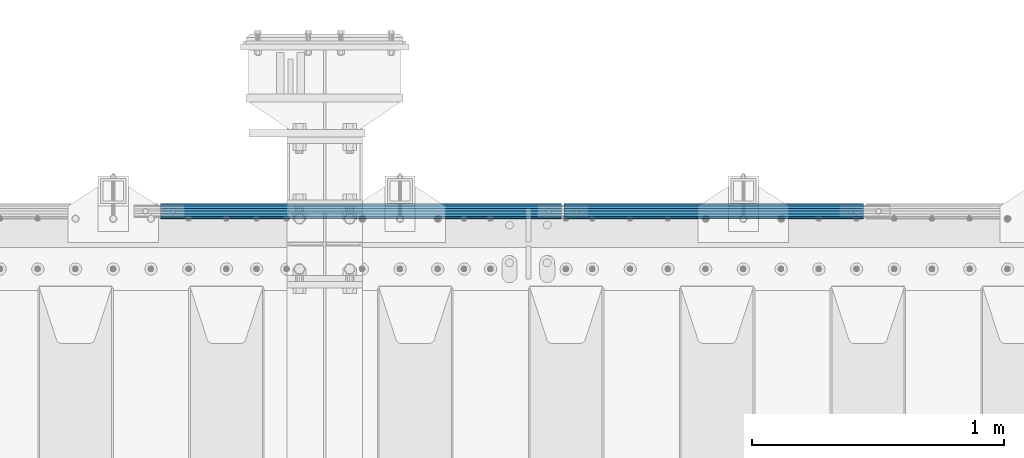
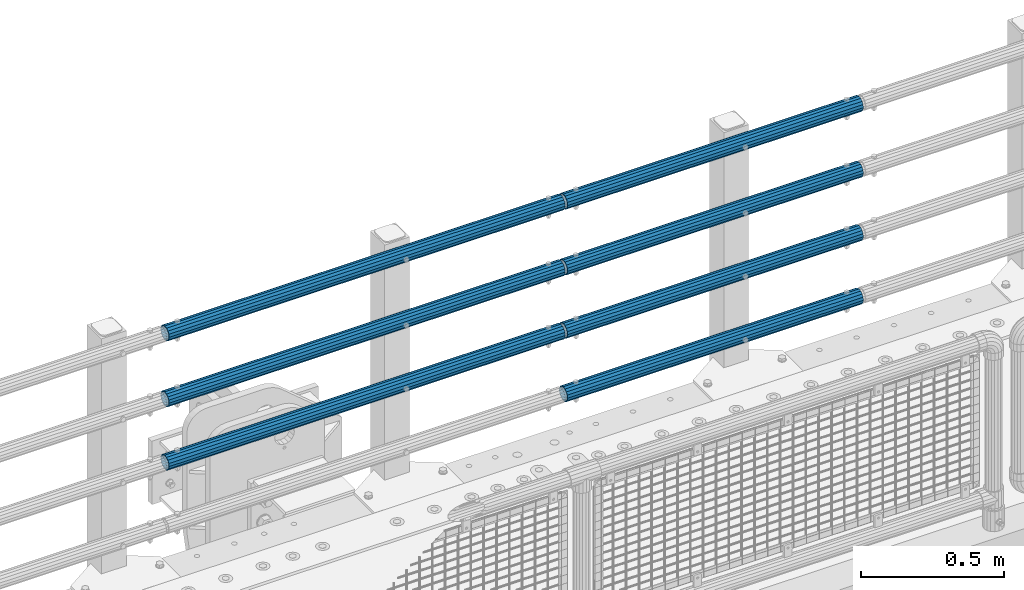
# One storey, part 127 of 240: 7 beams.
"""IFC2X3 building model written with IfcOpenShell, lengths in millimetres."""

from ifc_helpers import new_model, si_unit, frame, origin_with_axes, place, context, subcontext, project, spatial, faceted_brep, material, type_object, element, save


model = new_model("IFC2X3")

# Units and contexts
model_context = context("Model", 3, precision=1e-05, world=origin_with_axes())
body_context = subcontext(model_context, "Body", "Model", "MODEL_VIEW")
ifc_project = project(units=[si_unit("LENGTHUNIT", "METRE", prefix="MILLI"), si_unit("AREAUNIT", "SQUARE_METRE"), si_unit("VOLUMEUNIT", "CUBIC_METRE"), si_unit("MASSUNIT", "GRAM", prefix="KILO"), si_unit("TIMEUNIT", "SECOND"), si_unit("PLANEANGLEUNIT", "RADIAN"), si_unit("SOLIDANGLEUNIT", "STERADIAN"), si_unit("THERMODYNAMICTEMPERATUREUNIT", "DEGREE_CELSIUS"), si_unit("LUMINOUSINTENSITYUNIT", "LUMEN")], contexts=[model_context])

# Site, building, storey
site_placement = place(None, origin_with_axes())
site = spatial("IfcSite", under=ifc_project, at=site_placement, CompositionType="ELEMENT")
building_placement = place(site_placement, origin_with_axes())
building = spatial("IfcBuilding", under=site, at=building_placement, Name="Standard", CompositionType="ELEMENT")
storey_placement = place(building_placement, origin_with_axes())
storey = spatial("IfcBuildingStorey", under=building, at=storey_placement, Name="Undefined", CompositionType="ELEMENT", Elevation=0.0)

# Beams
ifc_material = material()
beam_type = type_object("IfcBeamType", PredefinedType="NOTDEFINED")
beam_1_placement = place(storey_placement, frame((53781.9999999999, 36129.8500000002, 420.149999999748), z_axis=(0.0, 0.0, -1.0), x_axis=(-1.0, 0.0, 0.0)))
element("IfcBeam", 1, at=beam_1_placement, inside=storey, type_object=beam_type, material=ifc_material, context=body_context, shape_type="Brep", body=[
    faceted_brep([(0.0, -26.5500000000029, 0.0), (0.0, -24.5290015881765, 10.1602451292931), (1594.0, -24.5290015881765, 10.1602451292931), (1594.0, -26.5500000000029, 0.0), (0.0, -18.7736850405054, 18.7736850405028), (1594.0, -18.7736850405054, 18.7736850405028), (0.0, -10.1602451292929, 24.5290015881747), (1594.0, -10.1602451292929, 24.5290015881747), (0.0, 0.0, 26.55), (1594.0, 0.0, 26.55), (0.0, 10.1602451292929, 24.5290015881747), (1594.0, 10.1602451292929, 24.5290015881747), (0.0, 18.7736850405054, 18.7736850405028), (1594.0, 18.7736850405054, 18.7736850405028), (0.0, 24.5290015881765, 10.1602451292931), (1594.0, 24.5290015881765, 10.1602451292931), (0.0, 26.5500000000029, 0.0), (1594.0, 26.5500000000029, 0.0), (0.0, 24.5290015881765, -10.1602451292931), (1594.0, 24.5290015881765, -10.1602451292931), (0.0, 18.7736850405054, -18.7736850405028), (1594.0, 18.7736850405054, -18.7736850405028), (0.0, 10.1602451292929, -24.5290015881747), (1594.0, 10.1602451292929, -24.5290015881747), (0.0, 0.0, -26.55), (1594.0, 0.0, -26.55), (0.0, -10.1602451292929, -24.5290015881747), (1594.0, -10.1602451292929, -24.5290015881747), (0.0, -18.7736850405054, -18.7736850405028), (1594.0, -18.7736850405054, -18.7736850405028), (0.0, -24.5290015881765, -10.1602451292931), (1594.0, -24.5290015881765, -10.1602451292931), (0.0, -30.1500000000015, 0.0), (0.0, -27.8549679052157, -11.5379054858058), (1594.0, -27.8549679052157, -11.5379054858075), (1594.0, -30.1500000000015, 0.0), (0.0, -21.3192694527752, -21.3192694527752), (1594.0, -21.3192694527752, -21.3192694527744), (0.0, -11.5379054858058, -27.8549679052157), (1594.0, -11.5379054858058, -27.8549679052153), (0.0, 0.0, -30.1500000000015), (1594.0, 0.0, -30.15), (0.0, 11.5379054858058, -27.8549679052157), (1594.0, 11.5379054858058, -27.8549679052153), (0.0, 21.3192694527752, -21.3192694527752), (1594.0, 21.3192694527752, -21.3192694527744), (0.0, 27.8549679052157, -11.5379054858058), (1594.0, 27.8549679052157, -11.5379054858074), (0.0, 30.1500000000015, 0.0), (1594.0, 30.1500000000015, 0.0), (0.0, 27.8549679052157, 11.5379054858058), (1594.0, 27.8549679052157, 11.5379054858075), (0.0, 21.3192694527752, 21.3192694527752), (1594.0, 21.3192694527752, 21.3192694527744), (0.0, 11.5379054858058, 27.8549679052157), (1594.0, 11.5379054858058, 27.8549679052153), (0.0, 0.0, 30.1500000000015), (1594.0, 0.0, 30.15), (0.0, -11.5379054858058, 27.8549679052157), (1594.0, -11.5379054858058, 27.8549679052153), (0.0, -21.3192694527752, 21.3192694527752), (1594.0, -21.3192694527752, 21.3192694527744), (0.0, -27.8549679052157, 11.5379054858058), (1594.0, -27.8549679052157, 11.5379054858075)], [[[0, 1, 2, 3]], [[1, 4, 5, 2]], [[4, 6, 7, 5]], [[6, 8, 9, 7]], [[8, 10, 11, 9]], [[10, 12, 13, 11]], [[12, 14, 15, 13]], [[14, 16, 17, 15]], [[16, 18, 19, 17]], [[18, 20, 21, 19]], [[20, 22, 23, 21]], [[22, 24, 25, 23]], [[24, 26, 27, 25]], [[26, 28, 29, 27]], [[28, 30, 31, 29]], [[30, 0, 3, 31]], [[32, 33, 34, 35]], [[33, 36, 37, 34]], [[36, 38, 39, 37]], [[38, 40, 41, 39]], [[40, 42, 43, 41]], [[42, 44, 45, 43]], [[44, 46, 47, 45]], [[46, 48, 49, 47]], [[48, 50, 51, 49]], [[50, 52, 53, 51]], [[52, 54, 55, 53]], [[54, 56, 57, 55]], [[56, 58, 59, 57]], [[58, 60, 61, 59]], [[60, 62, 63, 61]], [[62, 32, 35, 63]], [[37, 39, 41, 43, 45, 47, 49, 51, 53, 55, 57, 59, 61, 63, 35, 34], [5, 7, 9, 11, 13, 15, 17, 19, 21, 23, 25, 27, 29, 31, 3, 2]], [[62, 60, 58, 56, 54, 52, 50, 48, 46, 44, 42, 40, 38, 36, 33, 32], [30, 28, 26, 24, 22, 20, 18, 16, 14, 12, 10, 8, 6, 4, 1, 0]]]),
])
beam_2_placement = place(storey_placement, frame((53781.9999999999, 36129.8500000002, 969.849999999748), z_axis=(0.0, 0.0, -1.0), x_axis=(-1.0, 0.0, 0.0)))
element("IfcBeam", 2, at=beam_2_placement, inside=storey, type_object=beam_type, material=ifc_material, context=body_context, shape_type="Brep", body=[
    faceted_brep([(0.0, -26.5500000000029, 0.0), (0.0, -24.5290015881765, 10.1602451292931), (1594.0, -24.5290015881765, 10.1602451292931), (1594.0, -26.5500000000029, 0.0), (0.0, -18.7736850405054, 18.7736850405028), (1594.0, -18.7736850405054, 18.7736850405028), (0.0, -10.1602451292929, 24.5290015881747), (1594.0, -10.1602451292929, 24.5290015881747), (0.0, 0.0, 26.55), (1594.0, 0.0, 26.55), (0.0, 10.1602451292929, 24.5290015881747), (1594.0, 10.1602451292929, 24.5290015881747), (0.0, 18.7736850405054, 18.7736850405028), (1594.0, 18.7736850405054, 18.7736850405028), (0.0, 24.5290015881765, 10.1602451292931), (1594.0, 24.5290015881765, 10.1602451292931), (0.0, 26.5500000000029, 0.0), (1594.0, 26.5500000000029, 0.0), (0.0, 24.5290015881765, -10.1602451292931), (1594.0, 24.5290015881765, -10.1602451292931), (0.0, 18.7736850405054, -18.7736850405028), (1594.0, 18.7736850405054, -18.7736850405028), (0.0, 10.1602451292929, -24.5290015881747), (1594.0, 10.1602451292929, -24.5290015881747), (0.0, 0.0, -26.55), (1594.0, 0.0, -26.55), (0.0, -10.1602451292929, -24.5290015881747), (1594.0, -10.1602451292929, -24.5290015881747), (0.0, -18.7736850405054, -18.7736850405028), (1594.0, -18.7736850405054, -18.7736850405028), (0.0, -24.5290015881765, -10.1602451292931), (1594.0, -24.5290015881765, -10.1602451292931), (0.0, -30.1500000000015, 0.0), (0.0, -27.8549679052157, -11.5379054858058), (1594.0, -27.8549679052157, -11.5379054858075), (1594.0, -30.1500000000015, 0.0), (0.0, -21.3192694527752, -21.3192694527752), (1594.0, -21.3192694527752, -21.3192694527744), (0.0, -11.5379054858058, -27.8549679052157), (1594.0, -11.5379054858058, -27.8549679052153), (0.0, 0.0, -30.1500000000015), (1594.0, 0.0, -30.15), (0.0, 11.5379054858058, -27.8549679052157), (1594.0, 11.5379054858058, -27.8549679052153), (0.0, 21.3192694527752, -21.3192694527752), (1594.0, 21.3192694527752, -21.3192694527744), (0.0, 27.8549679052157, -11.5379054858058), (1594.0, 27.8549679052157, -11.5379054858074), (0.0, 30.1500000000015, 0.0), (1594.0, 30.1500000000015, 0.0), (0.0, 27.8549679052157, 11.5379054858058), (1594.0, 27.8549679052157, 11.5379054858075), (0.0, 21.3192694527752, 21.3192694527752), (1594.0, 21.3192694527752, 21.3192694527744), (0.0, 11.5379054858058, 27.8549679052157), (1594.0, 11.5379054858058, 27.8549679052153), (0.0, 0.0, 30.1500000000015), (1594.0, 0.0, 30.15), (0.0, -11.5379054858058, 27.8549679052157), (1594.0, -11.5379054858058, 27.8549679052153), (0.0, -21.3192694527752, 21.3192694527752), (1594.0, -21.3192694527752, 21.3192694527744), (0.0, -27.8549679052157, 11.5379054858058), (1594.0, -27.8549679052157, 11.5379054858075)], [[[0, 1, 2, 3]], [[1, 4, 5, 2]], [[4, 6, 7, 5]], [[6, 8, 9, 7]], [[8, 10, 11, 9]], [[10, 12, 13, 11]], [[12, 14, 15, 13]], [[14, 16, 17, 15]], [[16, 18, 19, 17]], [[18, 20, 21, 19]], [[20, 22, 23, 21]], [[22, 24, 25, 23]], [[24, 26, 27, 25]], [[26, 28, 29, 27]], [[28, 30, 31, 29]], [[30, 0, 3, 31]], [[32, 33, 34, 35]], [[33, 36, 37, 34]], [[36, 38, 39, 37]], [[38, 40, 41, 39]], [[40, 42, 43, 41]], [[42, 44, 45, 43]], [[44, 46, 47, 45]], [[46, 48, 49, 47]], [[48, 50, 51, 49]], [[50, 52, 53, 51]], [[52, 54, 55, 53]], [[54, 56, 57, 55]], [[56, 58, 59, 57]], [[58, 60, 61, 59]], [[60, 62, 63, 61]], [[62, 32, 35, 63]], [[37, 39, 41, 43, 45, 47, 49, 51, 53, 55, 57, 59, 61, 63, 35, 34], [5, 7, 9, 11, 13, 15, 17, 19, 21, 23, 25, 27, 29, 31, 3, 2]], [[62, 60, 58, 56, 54, 52, 50, 48, 46, 44, 42, 40, 38, 36, 33, 32], [30, 28, 26, 24, 22, 20, 18, 16, 14, 12, 10, 8, 6, 4, 1, 0]]]),
])
beam_3_placement = place(storey_placement, frame((53792.0000000001, 36129.8499999996, 419.849999999748), z_axis=(0.0, -1.0, 0.0), x_axis=(1.0, 0.0, 0.0)))
element("IfcBeam", 3, at=beam_3_placement, inside=storey, type_object=beam_type, material=ifc_material, context=body_context, shape_type="Brep", body=[
    faceted_brep([(0.0, -26.5500000000029, 0.0), (0.0, -24.5290015881765, 10.1602451292931), (1190.0, -24.5290015881747, 10.1602451292929), (1190.0, -26.55, 0.0), (0.0, -18.7736850405054, 18.7736850405028), (1190.0, -18.7736850405028, 18.7736850405054), (0.0, -10.1602451292929, 24.5290015881747), (1190.0, -10.1602451292931, 24.5290015881765), (0.0, 0.0, 26.55), (1190.0, 0.0, 26.5500000000029), (0.0, 10.1602451292929, 24.5290015881747), (1190.0, 10.1602451292932, 24.5290015881765), (0.0, 18.7736850405054, 18.7736850405028), (1190.0, 18.7736850405029, 18.7736850405054), (0.0, 24.5290015881765, 10.1602451292931), (1190.0, 24.5290015881747, 10.1602451292929), (0.0, 26.5500000000029, 0.0), (1190.0, 26.55, 0.0), (0.0, 24.5290015881765, -10.1602451292931), (1190.0, 24.5290015881747, -10.1602451292929), (0.0, 18.7736850405054, -18.7736850405028), (1190.0, 18.7736850405028, -18.7736850405054), (0.0, 10.1602451292929, -24.5290015881747), (1190.0, 10.1602451292931, -24.5290015881765), (0.0, 0.0, -26.55), (1190.0, 0.0, -26.5500000000029), (0.0, -10.1602451292929, -24.5290015881747), (1190.0, -10.1602451292931, -24.5290015881765), (0.0, -18.7736850405054, -18.7736850405028), (1190.0, -18.7736850405028, -18.7736850405054), (0.0, -24.5290015881765, -10.1602451292931), (1190.0, -24.5290015881747, -10.1602451292929), (0.0, -30.1500000000015, 0.0), (0.0, -27.8549679052157, -11.5379054858058), (1190.0, -27.8549679052153, -11.5379054858058), (1190.0, -30.15, 0.0), (0.0, -21.3192694527752, -21.3192694527752), (1190.0, -21.3192694527744, -21.3192694527752), (0.0, -11.5379054858058, -27.8549679052157), (1190.0, -11.5379054858075, -27.8549679052157), (0.0, 0.0, -30.1500000000015), (1190.0, 0.0, -30.1500000000015), (0.0, 11.5379054858058, -27.8549679052157), (1190.0, 11.5379054858075, -27.8549679052157), (0.0, 21.3192694527752, -21.3192694527752), (1190.0, 21.3192694527744, -21.3192694527752), (0.0, 27.8549679052157, -11.5379054858058), (1190.0, 27.8549679052153, -11.5379054858058), (0.0, 30.1500000000015, 0.0), (1190.0, 30.15, 0.0), (0.0, 27.8549679052157, 11.5379054858058), (1190.0, 27.8549679052153, 11.5379054858058), (0.0, 21.3192694527752, 21.3192694527752), (1190.0, 21.3192694527744, 21.3192694527752), (0.0, 11.5379054858058, 27.8549679052157), (1190.0, 11.5379054858075, 27.8549679052157), (0.0, 0.0, 30.1500000000015), (1190.0, 0.0, 30.1500000000015), (0.0, -11.5379054858058, 27.8549679052157), (1190.0, -11.5379054858075, 27.8549679052157), (0.0, -21.3192694527752, 21.3192694527752), (1190.0, -21.3192694527744, 21.3192694527752), (0.0, -27.8549679052157, 11.5379054858058), (1190.0, -27.8549679052153, 11.5379054858058)], [[[0, 1, 2, 3]], [[1, 4, 5, 2]], [[4, 6, 7, 5]], [[6, 8, 9, 7]], [[8, 10, 11, 9]], [[10, 12, 13, 11]], [[12, 14, 15, 13]], [[14, 16, 17, 15]], [[16, 18, 19, 17]], [[18, 20, 21, 19]], [[20, 22, 23, 21]], [[22, 24, 25, 23]], [[24, 26, 27, 25]], [[26, 28, 29, 27]], [[28, 30, 31, 29]], [[30, 0, 3, 31]], [[32, 33, 34, 35]], [[33, 36, 37, 34]], [[36, 38, 39, 37]], [[38, 40, 41, 39]], [[40, 42, 43, 41]], [[42, 44, 45, 43]], [[44, 46, 47, 45]], [[46, 48, 49, 47]], [[48, 50, 51, 49]], [[50, 52, 53, 51]], [[52, 54, 55, 53]], [[54, 56, 57, 55]], [[56, 58, 59, 57]], [[58, 60, 61, 59]], [[60, 62, 63, 61]], [[62, 32, 35, 63]], [[37, 39, 41, 43, 45, 47, 49, 51, 53, 55, 57, 59, 61, 63, 35, 34], [5, 7, 9, 11, 13, 15, 17, 19, 21, 23, 25, 27, 29, 31, 3, 2]], [[62, 60, 58, 56, 54, 52, 50, 48, 46, 44, 42, 40, 38, 36, 33, 32], [30, 28, 26, 24, 22, 20, 18, 16, 14, 12, 10, 8, 6, 4, 1, 0]]]),
])
beam_4_placement = place(storey_placement, frame((53792.0000000001, 36129.8499999996, 149.549999999748), z_axis=(0.0, -1.0, 0.0), x_axis=(1.0, 0.0, 0.0)))
element("IfcBeam", 4, at=beam_4_placement, inside=storey, type_object=beam_type, material=ifc_material, context=body_context, shape_type="Brep", body=[
    faceted_brep([(0.0, -26.5500000000029, 0.0), (0.0, -24.5290015881765, 10.1602451292931), (1190.0, -24.5290015881747, 10.1602451292929), (1190.0, -26.55, 0.0), (0.0, -18.7736850405054, 18.7736850405028), (1190.0, -18.7736850405028, 18.7736850405054), (0.0, -10.1602451292929, 24.5290015881747), (1190.0, -10.1602451292931, 24.5290015881765), (0.0, 0.0, 26.55), (1190.0, 0.0, 26.5500000000029), (0.0, 10.1602451292929, 24.5290015881747), (1190.0, 10.1602451292932, 24.5290015881765), (0.0, 18.7736850405054, 18.7736850405028), (1190.0, 18.7736850405029, 18.7736850405054), (0.0, 24.5290015881765, 10.1602451292931), (1190.0, 24.5290015881747, 10.1602451292929), (0.0, 26.5500000000029, 0.0), (1190.0, 26.55, 0.0), (0.0, 24.5290015881765, -10.1602451292931), (1190.0, 24.5290015881747, -10.1602451292929), (0.0, 18.7736850405054, -18.7736850405028), (1190.0, 18.7736850405028, -18.7736850405054), (0.0, 10.1602451292929, -24.5290015881747), (1190.0, 10.1602451292931, -24.5290015881765), (0.0, 0.0, -26.55), (1190.0, 0.0, -26.5500000000029), (0.0, -10.1602451292929, -24.5290015881747), (1190.0, -10.1602451292931, -24.5290015881765), (0.0, -18.7736850405054, -18.7736850405028), (1190.0, -18.7736850405028, -18.7736850405054), (0.0, -24.5290015881765, -10.1602451292931), (1190.0, -24.5290015881747, -10.1602451292929), (0.0, -30.1500000000015, 0.0), (0.0, -27.8549679052157, -11.5379054858058), (1190.0, -27.8549679052153, -11.5379054858058), (1190.0, -30.15, 0.0), (0.0, -21.3192694527752, -21.3192694527752), (1190.0, -21.3192694527744, -21.3192694527752), (0.0, -11.5379054858058, -27.8549679052157), (1190.0, -11.5379054858075, -27.8549679052157), (0.0, 0.0, -30.1500000000015), (1190.0, 0.0, -30.1500000000015), (0.0, 11.5379054858058, -27.8549679052157), (1190.0, 11.5379054858075, -27.8549679052157), (0.0, 21.3192694527752, -21.3192694527752), (1190.0, 21.3192694527744, -21.3192694527752), (0.0, 27.8549679052157, -11.5379054858058), (1190.0, 27.8549679052153, -11.5379054858058), (0.0, 30.1500000000015, 0.0), (1190.0, 30.15, 0.0), (0.0, 27.8549679052157, 11.5379054858058), (1190.0, 27.8549679052153, 11.5379054858058), (0.0, 21.3192694527752, 21.3192694527752), (1190.0, 21.3192694527744, 21.3192694527752), (0.0, 11.5379054858058, 27.8549679052157), (1190.0, 11.5379054858075, 27.8549679052157), (0.0, 0.0, 30.1500000000015), (1190.0, 0.0, 30.1500000000015), (0.0, -11.5379054858058, 27.8549679052157), (1190.0, -11.5379054858075, 27.8549679052157), (0.0, -21.3192694527752, 21.3192694527752), (1190.0, -21.3192694527744, 21.3192694527752), (0.0, -27.8549679052157, 11.5379054858058), (1190.0, -27.8549679052153, 11.5379054858058)], [[[0, 1, 2, 3]], [[1, 4, 5, 2]], [[4, 6, 7, 5]], [[6, 8, 9, 7]], [[8, 10, 11, 9]], [[10, 12, 13, 11]], [[12, 14, 15, 13]], [[14, 16, 17, 15]], [[16, 18, 19, 17]], [[18, 20, 21, 19]], [[20, 22, 23, 21]], [[22, 24, 25, 23]], [[24, 26, 27, 25]], [[26, 28, 29, 27]], [[28, 30, 31, 29]], [[30, 0, 3, 31]], [[32, 33, 34, 35]], [[33, 36, 37, 34]], [[36, 38, 39, 37]], [[38, 40, 41, 39]], [[40, 42, 43, 41]], [[42, 44, 45, 43]], [[44, 46, 47, 45]], [[46, 48, 49, 47]], [[48, 50, 51, 49]], [[50, 52, 53, 51]], [[52, 54, 55, 53]], [[54, 56, 57, 55]], [[56, 58, 59, 57]], [[58, 60, 61, 59]], [[60, 62, 63, 61]], [[62, 32, 35, 63]], [[37, 39, 41, 43, 45, 47, 49, 51, 53, 55, 57, 59, 61, 63, 35, 34], [5, 7, 9, 11, 13, 15, 17, 19, 21, 23, 25, 27, 29, 31, 3, 2]], [[62, 60, 58, 56, 54, 52, 50, 48, 46, 44, 42, 40, 38, 36, 33, 32], [30, 28, 26, 24, 22, 20, 18, 16, 14, 12, 10, 8, 6, 4, 1, 0]]]),
])
beam_5_placement = place(storey_placement, frame((53792.0000000001, 36129.8499999996, 969.549999999748), z_axis=(0.0, -1.0, 0.0), x_axis=(1.0, 0.0, 0.0)))
element("IfcBeam", 5, at=beam_5_placement, inside=storey, type_object=beam_type, material=ifc_material, context=body_context, shape_type="Brep", body=[
    faceted_brep([(0.0, -26.5500000000029, 0.0), (0.0, -24.5290015881765, 10.1602451292931), (1190.0, -24.5290015881747, 10.1602451292929), (1190.0, -26.55, 0.0), (0.0, -18.7736850405054, 18.7736850405028), (1190.0, -18.7736850405028, 18.7736850405054), (0.0, -10.1602451292929, 24.5290015881747), (1190.0, -10.1602451292931, 24.5290015881765), (0.0, 0.0, 26.55), (1190.0, 0.0, 26.5500000000029), (0.0, 10.1602451292929, 24.5290015881747), (1190.0, 10.1602451292932, 24.5290015881765), (0.0, 18.7736850405054, 18.7736850405028), (1190.0, 18.7736850405029, 18.7736850405054), (0.0, 24.5290015881765, 10.1602451292931), (1190.0, 24.5290015881747, 10.1602451292929), (0.0, 26.5500000000029, 0.0), (1190.0, 26.55, 0.0), (0.0, 24.5290015881765, -10.1602451292931), (1190.0, 24.5290015881747, -10.1602451292929), (0.0, 18.7736850405054, -18.7736850405028), (1190.0, 18.7736850405028, -18.7736850405054), (0.0, 10.1602451292929, -24.5290015881747), (1190.0, 10.1602451292931, -24.5290015881765), (0.0, 0.0, -26.55), (1190.0, 0.0, -26.5500000000029), (0.0, -10.1602451292929, -24.5290015881747), (1190.0, -10.1602451292931, -24.5290015881765), (0.0, -18.7736850405054, -18.7736850405028), (1190.0, -18.7736850405028, -18.7736850405054), (0.0, -24.5290015881765, -10.1602451292931), (1190.0, -24.5290015881747, -10.1602451292929), (0.0, -30.1500000000015, 0.0), (0.0, -27.8549679052157, -11.5379054858058), (1190.0, -27.8549679052153, -11.5379054858058), (1190.0, -30.15, 0.0), (0.0, -21.3192694527752, -21.3192694527752), (1190.0, -21.3192694527744, -21.3192694527752), (0.0, -11.5379054858058, -27.8549679052157), (1190.0, -11.5379054858075, -27.8549679052157), (0.0, 0.0, -30.1500000000015), (1190.0, 0.0, -30.1500000000015), (0.0, 11.5379054858058, -27.8549679052157), (1190.0, 11.5379054858075, -27.8549679052157), (0.0, 21.3192694527752, -21.3192694527752), (1190.0, 21.3192694527744, -21.3192694527752), (0.0, 27.8549679052157, -11.5379054858058), (1190.0, 27.8549679052153, -11.5379054858058), (0.0, 30.1500000000015, 0.0), (1190.0, 30.15, 0.0), (0.0, 27.8549679052157, 11.5379054858058), (1190.0, 27.8549679052153, 11.5379054858058), (0.0, 21.3192694527752, 21.3192694527752), (1190.0, 21.3192694527744, 21.3192694527752), (0.0, 11.5379054858058, 27.8549679052157), (1190.0, 11.5379054858075, 27.8549679052157), (0.0, 0.0, 30.1500000000015), (1190.0, 0.0, 30.1500000000015), (0.0, -11.5379054858058, 27.8549679052157), (1190.0, -11.5379054858075, 27.8549679052157), (0.0, -21.3192694527752, 21.3192694527752), (1190.0, -21.3192694527744, 21.3192694527752), (0.0, -27.8549679052157, 11.5379054858058), (1190.0, -27.8549679052153, 11.5379054858058)], [[[0, 1, 2, 3]], [[1, 4, 5, 2]], [[4, 6, 7, 5]], [[6, 8, 9, 7]], [[8, 10, 11, 9]], [[10, 12, 13, 11]], [[12, 14, 15, 13]], [[14, 16, 17, 15]], [[16, 18, 19, 17]], [[18, 20, 21, 19]], [[20, 22, 23, 21]], [[22, 24, 25, 23]], [[24, 26, 27, 25]], [[26, 28, 29, 27]], [[28, 30, 31, 29]], [[30, 0, 3, 31]], [[32, 33, 34, 35]], [[33, 36, 37, 34]], [[36, 38, 39, 37]], [[38, 40, 41, 39]], [[40, 42, 43, 41]], [[42, 44, 45, 43]], [[44, 46, 47, 45]], [[46, 48, 49, 47]], [[48, 50, 51, 49]], [[50, 52, 53, 51]], [[52, 54, 55, 53]], [[54, 56, 57, 55]], [[56, 58, 59, 57]], [[58, 60, 61, 59]], [[60, 62, 63, 61]], [[62, 32, 35, 63]], [[37, 39, 41, 43, 45, 47, 49, 51, 53, 55, 57, 59, 61, 63, 35, 34], [5, 7, 9, 11, 13, 15, 17, 19, 21, 23, 25, 27, 29, 31, 3, 2]], [[62, 60, 58, 56, 54, 52, 50, 48, 46, 44, 42, 40, 38, 36, 33, 32], [30, 28, 26, 24, 22, 20, 18, 16, 14, 12, 10, 8, 6, 4, 1, 0]]]),
])
beam_6_placement = place(storey_placement, frame((53792.0000000001, 36129.8499999996, 689.549999999748), z_axis=(0.0, -1.0, 0.0), x_axis=(1.0, 0.0, 0.0)))
element("IfcBeam", 6, at=beam_6_placement, inside=storey, type_object=beam_type, material=ifc_material, context=body_context, shape_type="Brep", body=[
    faceted_brep([(0.0, -26.5500000000029, 0.0), (0.0, -24.5290015881765, 10.1602451292931), (1190.0, -24.5290015881747, 10.1602451292929), (1190.0, -26.55, 0.0), (0.0, -18.7736850405054, 18.7736850405028), (1190.0, -18.7736850405028, 18.7736850405054), (0.0, -10.1602451292929, 24.5290015881747), (1190.0, -10.1602451292931, 24.5290015881765), (0.0, 0.0, 26.55), (1190.0, 0.0, 26.5500000000029), (0.0, 10.1602451292929, 24.5290015881747), (1190.0, 10.1602451292932, 24.5290015881765), (0.0, 18.7736850405054, 18.7736850405028), (1190.0, 18.7736850405029, 18.7736850405054), (0.0, 24.5290015881765, 10.1602451292931), (1190.0, 24.5290015881747, 10.1602451292929), (0.0, 26.5500000000029, 0.0), (1190.0, 26.55, 0.0), (0.0, 24.5290015881765, -10.1602451292931), (1190.0, 24.5290015881747, -10.1602451292929), (0.0, 18.7736850405054, -18.7736850405028), (1190.0, 18.7736850405028, -18.7736850405054), (0.0, 10.1602451292929, -24.5290015881747), (1190.0, 10.1602451292931, -24.5290015881765), (0.0, 0.0, -26.55), (1190.0, 0.0, -26.5500000000029), (0.0, -10.1602451292929, -24.5290015881747), (1190.0, -10.1602451292931, -24.5290015881765), (0.0, -18.7736850405054, -18.7736850405028), (1190.0, -18.7736850405028, -18.7736850405054), (0.0, -24.5290015881765, -10.1602451292931), (1190.0, -24.5290015881747, -10.1602451292929), (0.0, -30.1500000000015, 0.0), (0.0, -27.8549679052157, -11.5379054858058), (1190.0, -27.8549679052153, -11.5379054858058), (1190.0, -30.15, 0.0), (0.0, -21.3192694527752, -21.3192694527752), (1190.0, -21.3192694527744, -21.3192694527752), (0.0, -11.5379054858058, -27.8549679052157), (1190.0, -11.5379054858075, -27.8549679052157), (0.0, 0.0, -30.1500000000015), (1190.0, 0.0, -30.1500000000015), (0.0, 11.5379054858058, -27.8549679052157), (1190.0, 11.5379054858075, -27.8549679052157), (0.0, 21.3192694527752, -21.3192694527752), (1190.0, 21.3192694527744, -21.3192694527752), (0.0, 27.8549679052157, -11.5379054858058), (1190.0, 27.8549679052153, -11.5379054858058), (0.0, 30.1500000000015, 0.0), (1190.0, 30.15, 0.0), (0.0, 27.8549679052157, 11.5379054858058), (1190.0, 27.8549679052153, 11.5379054858058), (0.0, 21.3192694527752, 21.3192694527752), (1190.0, 21.3192694527744, 21.3192694527752), (0.0, 11.5379054858058, 27.8549679052157), (1190.0, 11.5379054858075, 27.8549679052157), (0.0, 0.0, 30.1500000000015), (1190.0, 0.0, 30.1500000000015), (0.0, -11.5379054858058, 27.8549679052157), (1190.0, -11.5379054858075, 27.8549679052157), (0.0, -21.3192694527752, 21.3192694527752), (1190.0, -21.3192694527744, 21.3192694527752), (0.0, -27.8549679052157, 11.5379054858058), (1190.0, -27.8549679052153, 11.5379054858058)], [[[0, 1, 2, 3]], [[1, 4, 5, 2]], [[4, 6, 7, 5]], [[6, 8, 9, 7]], [[8, 10, 11, 9]], [[10, 12, 13, 11]], [[12, 14, 15, 13]], [[14, 16, 17, 15]], [[16, 18, 19, 17]], [[18, 20, 21, 19]], [[20, 22, 23, 21]], [[22, 24, 25, 23]], [[24, 26, 27, 25]], [[26, 28, 29, 27]], [[28, 30, 31, 29]], [[30, 0, 3, 31]], [[32, 33, 34, 35]], [[33, 36, 37, 34]], [[36, 38, 39, 37]], [[38, 40, 41, 39]], [[40, 42, 43, 41]], [[42, 44, 45, 43]], [[44, 46, 47, 45]], [[46, 48, 49, 47]], [[48, 50, 51, 49]], [[50, 52, 53, 51]], [[52, 54, 55, 53]], [[54, 56, 57, 55]], [[56, 58, 59, 57]], [[58, 60, 61, 59]], [[60, 62, 63, 61]], [[62, 32, 35, 63]], [[37, 39, 41, 43, 45, 47, 49, 51, 53, 55, 57, 59, 61, 63, 35, 34], [5, 7, 9, 11, 13, 15, 17, 19, 21, 23, 25, 27, 29, 31, 3, 2]], [[62, 60, 58, 56, 54, 52, 50, 48, 46, 44, 42, 40, 38, 36, 33, 32], [30, 28, 26, 24, 22, 20, 18, 16, 14, 12, 10, 8, 6, 4, 1, 0]]]),
])
beam_7_placement = place(storey_placement, frame((53781.9999999999, 36129.8500000002, 689.849999999748), z_axis=(0.0, 0.0, -1.0), x_axis=(-1.0, 0.0, 0.0)))
element("IfcBeam", 7, at=beam_7_placement, inside=storey, type_object=beam_type, material=ifc_material, context=body_context, shape_type="Brep", body=[
    faceted_brep([(0.0, -26.5500000000029, 0.0), (0.0, -24.5290015881765, 10.1602451292931), (1594.0, -24.5290015881765, 10.1602451292931), (1594.0, -26.5500000000029, 0.0), (0.0, -18.7736850405054, 18.7736850405028), (1594.0, -18.7736850405054, 18.7736850405028), (0.0, -10.1602451292929, 24.5290015881747), (1594.0, -10.1602451292929, 24.5290015881747), (0.0, 0.0, 26.55), (1594.0, 0.0, 26.55), (0.0, 10.1602451292929, 24.5290015881747), (1594.0, 10.1602451292929, 24.5290015881747), (0.0, 18.7736850405054, 18.7736850405028), (1594.0, 18.7736850405054, 18.7736850405028), (0.0, 24.5290015881765, 10.1602451292931), (1594.0, 24.5290015881765, 10.1602451292931), (0.0, 26.5500000000029, 0.0), (1594.0, 26.5500000000029, 0.0), (0.0, 24.5290015881765, -10.1602451292931), (1594.0, 24.5290015881765, -10.1602451292931), (0.0, 18.7736850405054, -18.7736850405028), (1594.0, 18.7736850405054, -18.7736850405028), (0.0, 10.1602451292929, -24.5290015881747), (1594.0, 10.1602451292929, -24.5290015881747), (0.0, 0.0, -26.55), (1594.0, 0.0, -26.55), (0.0, -10.1602451292929, -24.5290015881747), (1594.0, -10.1602451292929, -24.5290015881747), (0.0, -18.7736850405054, -18.7736850405028), (1594.0, -18.7736850405054, -18.7736850405028), (0.0, -24.5290015881765, -10.1602451292931), (1594.0, -24.5290015881765, -10.1602451292931), (0.0, -30.1500000000015, 0.0), (0.0, -27.8549679052157, -11.5379054858058), (1594.0, -27.8549679052157, -11.5379054858075), (1594.0, -30.1500000000015, 0.0), (0.0, -21.3192694527752, -21.3192694527752), (1594.0, -21.3192694527752, -21.3192694527744), (0.0, -11.5379054858058, -27.8549679052157), (1594.0, -11.5379054858058, -27.8549679052153), (0.0, 0.0, -30.1500000000015), (1594.0, 0.0, -30.15), (0.0, 11.5379054858058, -27.8549679052157), (1594.0, 11.5379054858058, -27.8549679052153), (0.0, 21.3192694527752, -21.3192694527752), (1594.0, 21.3192694527752, -21.3192694527744), (0.0, 27.8549679052157, -11.5379054858058), (1594.0, 27.8549679052157, -11.5379054858074), (0.0, 30.1500000000015, 0.0), (1594.0, 30.1500000000015, 0.0), (0.0, 27.8549679052157, 11.5379054858058), (1594.0, 27.8549679052157, 11.5379054858075), (0.0, 21.3192694527752, 21.3192694527752), (1594.0, 21.3192694527752, 21.3192694527744), (0.0, 11.5379054858058, 27.8549679052157), (1594.0, 11.5379054858058, 27.8549679052153), (0.0, 0.0, 30.1500000000015), (1594.0, 0.0, 30.15), (0.0, -11.5379054858058, 27.8549679052157), (1594.0, -11.5379054858058, 27.8549679052153), (0.0, -21.3192694527752, 21.3192694527752), (1594.0, -21.3192694527752, 21.3192694527744), (0.0, -27.8549679052157, 11.5379054858058), (1594.0, -27.8549679052157, 11.5379054858075)], [[[0, 1, 2, 3]], [[1, 4, 5, 2]], [[4, 6, 7, 5]], [[6, 8, 9, 7]], [[8, 10, 11, 9]], [[10, 12, 13, 11]], [[12, 14, 15, 13]], [[14, 16, 17, 15]], [[16, 18, 19, 17]], [[18, 20, 21, 19]], [[20, 22, 23, 21]], [[22, 24, 25, 23]], [[24, 26, 27, 25]], [[26, 28, 29, 27]], [[28, 30, 31, 29]], [[30, 0, 3, 31]], [[32, 33, 34, 35]], [[33, 36, 37, 34]], [[36, 38, 39, 37]], [[38, 40, 41, 39]], [[40, 42, 43, 41]], [[42, 44, 45, 43]], [[44, 46, 47, 45]], [[46, 48, 49, 47]], [[48, 50, 51, 49]], [[50, 52, 53, 51]], [[52, 54, 55, 53]], [[54, 56, 57, 55]], [[56, 58, 59, 57]], [[58, 60, 61, 59]], [[60, 62, 63, 61]], [[62, 32, 35, 63]], [[37, 39, 41, 43, 45, 47, 49, 51, 53, 55, 57, 59, 61, 63, 35, 34], [5, 7, 9, 11, 13, 15, 17, 19, 21, 23, 25, 27, 29, 31, 3, 2]], [[62, 60, 58, 56, 54, 52, 50, 48, 46, 44, 42, 40, 38, 36, 33, 32], [30, 28, 26, 24, 22, 20, 18, 16, 14, 12, 10, 8, 6, 4, 1, 0]]]),
])

save(model, "model.ifc")
